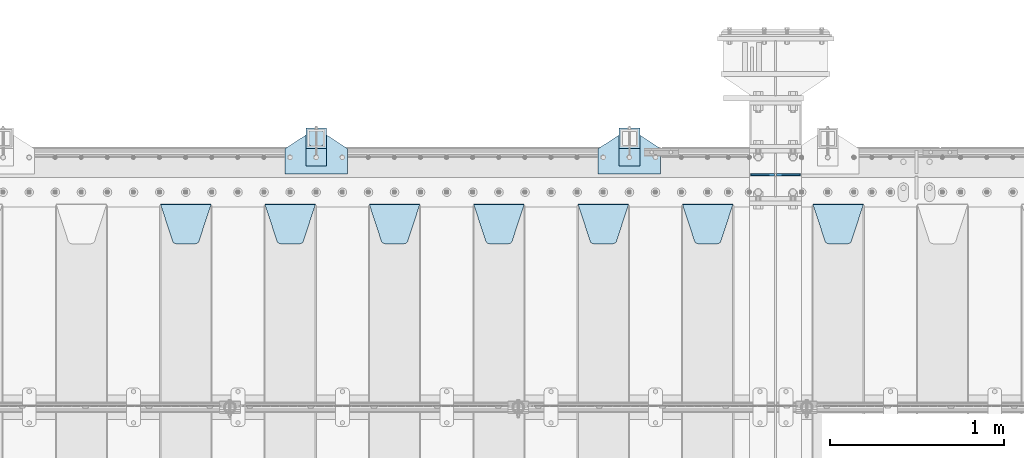
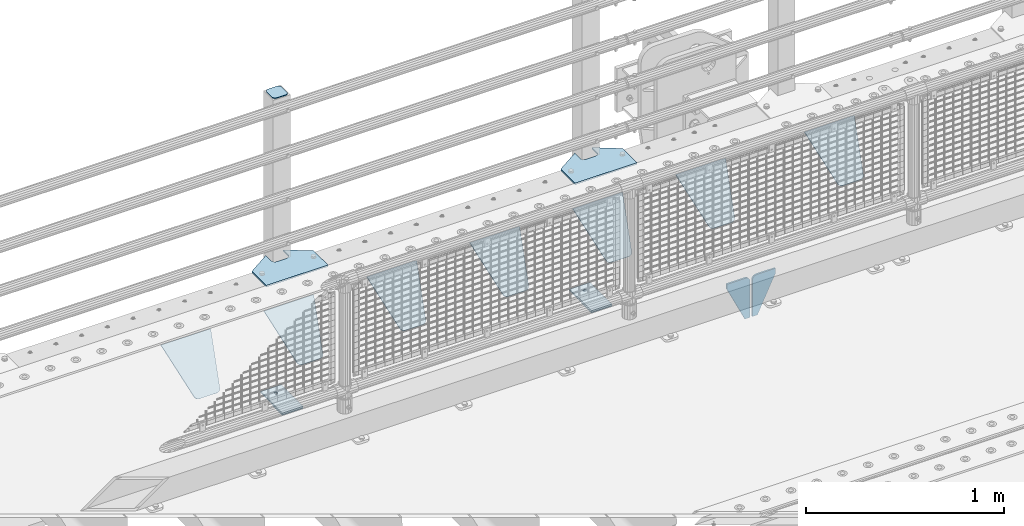
# One storey, part 224 of 240: 16 plates.
"""IFC2X3 building model written with IfcOpenShell, lengths in millimetres."""

from ifc_helpers import new_model, si_unit, frame, origin_with_axes, place, context, subcontext, project, spatial, faceted_brep, material, type_object, element, save


model = new_model("IFC2X3")

# Units and contexts
model_context = context("Model", 3, precision=1e-05, world=origin_with_axes())
body_context = subcontext(model_context, "Body", "Model", "MODEL_VIEW")
ifc_project = project(units=[si_unit("LENGTHUNIT", "METRE", prefix="MILLI"), si_unit("AREAUNIT", "SQUARE_METRE"), si_unit("VOLUMEUNIT", "CUBIC_METRE"), si_unit("MASSUNIT", "GRAM", prefix="KILO"), si_unit("TIMEUNIT", "SECOND"), si_unit("PLANEANGLEUNIT", "RADIAN"), si_unit("SOLIDANGLEUNIT", "STERADIAN"), si_unit("THERMODYNAMICTEMPERATUREUNIT", "DEGREE_CELSIUS"), si_unit("LUMINOUSINTENSITYUNIT", "LUMEN")], contexts=[model_context])

# Site, building, storey
site_placement = place(None, origin_with_axes())
site = spatial("IfcSite", under=ifc_project, at=site_placement, CompositionType="ELEMENT")
building_placement = place(site_placement, origin_with_axes())
building = spatial("IfcBuilding", under=site, at=building_placement, Name="Standard", CompositionType="ELEMENT")
storey_placement = place(building_placement, origin_with_axes())
storey = spatial("IfcBuildingStorey", under=building, at=storey_placement, Name="Undefined", CompositionType="ELEMENT", Elevation=0.0)

# Plates
ifc_material_1 = material(Name="STEEL/S355N")
plate_type_1 = type_object("IfcPlateType", PredefinedType="NOTDEFINED")
for number, where, z_axis, x_axis in (
    (1, (52833.499999996, 36000.0000000345, -915.000018222272), (0.0, 0.0, -1.0), (-1.0, 0.0, 0.0)),
    (2, (52846.4999999962, 36000.0000000345, -915.000018222272), (0.0, 0.0, -1.0), (1.0, 0.0, 0.0)),
):
    element("IfcPlate", number, at=place(storey_placement, frame(where, z_axis=z_axis, x_axis=x_axis)), inside=storey, type_object=plate_type_1, material=ifc_material_1, context=body_context, shape_type="Brep", body=[
        faceted_brep([(0.0, -5.0, 27.0), (0.0, -5.0, 250.0), (0.0, 5.0, 250.0), (0.0, 5.0, 27.0), (30.0, -5.0, 250.0), (30.0, 5.0, 250.0), (135.0, -5.0, 30.0), (135.0, 5.0, 30.0), (135.0, -5.0, 0.0), (135.0, 5.0, 0.0), (27.0, -5.0, 0.0), (27.0, 5.0, 0.0), (22.311499202995, -5.0, 0.410190668670339), (22.311499202995, 5.0, 0.410190668670339), (17.7654561302043, -5.0, 1.62829923878053), (17.7654561302043, 5.0, 1.62829923878053), (13.5, -5.0, 3.6173140978201), (13.5, 5.0, 3.6173140978201), (9.64473453846585, -5.0, 6.31680003578754), (9.64473453846585, 5.0, 6.31680003578754), (6.31680003579095, -5.0, 9.64473453846347), (6.31680003579095, 5.0, 9.64473453846347), (3.61731409782078, -5.0, 13.5), (3.61731409782078, 5.0, 13.5), (1.62829923877871, -5.0, 17.765456130207), (1.62829923877871, 5.0, 17.765456130207), (0.410190668670111, -5.0, 22.3114992029929), (0.410190668670111, 5.0, 22.3114992029929)], [[[0, 1, 2, 3]], [[1, 4, 5, 2]], [[4, 6, 7, 5]], [[6, 8, 9, 7]], [[8, 10, 11, 9]], [[10, 12, 13, 11]], [[12, 14, 15, 13]], [[14, 16, 17, 15]], [[16, 18, 19, 17]], [[18, 20, 21, 19]], [[20, 22, 23, 21]], [[22, 24, 25, 23]], [[24, 26, 27, 25]], [[26, 0, 3, 27]], [[5, 7, 9, 11, 13, 15, 17, 19, 21, 23, 25, 27, 3, 2]], [[26, 24, 22, 20, 18, 16, 14, 12, 10, 8, 6, 4, 1, 0]]]),
    ])
plate_type_2 = type_object("IfcPlateType", PredefinedType="NOTDEFINED")
plate_1_placement = place(storey_placement, frame((53055.0, 35831.767766956, -1.76776695296758), z_axis=(0.0, -0.707106781186547, -0.707106781186548), x_axis=(1.0, 0.0, 0.0)))
element("IfcPlate", 3, at=plate_1_placement, inside=storey, type_object=plate_type_2, material=ifc_material_1, context=body_context, shape_type="Brep", body=[
    faceted_brep([(0.0, -2.5, 0.0), (69.345504679477, -2.50000000000364, 300.171731424827), (69.345504679477, 2.49999999999636, 300.171731424827), (0.0, 2.5, 0.0), (70.927406119954, -2.50000000000364, 304.897442415397), (70.927406119954, 2.49999999999636, 304.897442415397), (73.3818627772271, -2.50000000000728, 309.234538108525), (73.3818627772271, 2.49999999999636, 309.234538108529), (76.6187032999587, -2.50000000000728, 313.023683126099), (76.6187032999587, 2.49999999999636, 313.023683126103), (80.5190132705029, -2.50000000000364, 316.125672595368), (80.5190132705029, 2.49999999999636, 316.125672595368), (84.9395038596849, -2.50000000000364, 318.426546230472), (84.9395038596849, 2.49999999999636, 318.426546230472), (89.7177759439219, -2.5, 319.841774983277), (89.7177759439219, 2.49999999999636, 319.841774983273), (94.6782862926484, -2.50000000000364, 320.319366455074), (94.6782862926484, 2.49999999999636, 320.319366455074), (195.321713707352, -2.50000000000364, 320.319366455074), (195.321713707352, 2.49999999999636, 320.319366455074), (200.282224056078, -2.50000000000364, 319.841774983273), (200.282224056078, 2.49999999999636, 319.841774983273), (205.060496140315, -2.50000000000364, 318.426546230472), (205.060496140315, 2.49999999999636, 318.426546230472), (209.480986729497, -2.50000000000364, 316.125672595368), (209.480986729497, 2.49999999999636, 316.125672595368), (213.381296700041, -2.50000000000728, 313.023683126099), (213.381296700041, 2.49999999999272, 313.023683126099), (216.618137222766, -2.50000000000364, 309.234538108522), (216.618137222766, 2.49999999999636, 309.234538108522), (219.072593880039, -2.50000000000364, 304.897442415397), (219.072593880039, 2.49999999999636, 304.897442415397), (220.654495320523, -2.50000000000364, 300.171731424827), (220.654495320523, 2.49999999999636, 300.171731424827), (290.0, -2.50000000000364, -3.63797880709171e-12), (290.0, 2.49999999999636, -3.63797880709171e-12)], [[[0, 1, 2, 3]], [[1, 4, 5, 2]], [[4, 6, 7, 5]], [[6, 8, 9, 7]], [[8, 10, 11, 9]], [[10, 12, 13, 11]], [[12, 14, 15, 13]], [[14, 16, 17, 15]], [[16, 18, 19, 17]], [[18, 20, 21, 19]], [[20, 22, 23, 21]], [[22, 24, 25, 23]], [[24, 26, 27, 25]], [[26, 28, 29, 27]], [[28, 30, 31, 29]], [[30, 32, 33, 31]], [[32, 34, 35, 33]], [[34, 0, 3, 35]], [[5, 7, 9, 11, 13, 15, 17, 19, 21, 23, 25, 27, 29, 31, 33, 35, 3, 2]], [[34, 32, 30, 28, 26, 24, 22, 20, 18, 16, 14, 12, 10, 8, 6, 4, 1, 0]]]),
])
plate_2_placement = place(storey_placement, frame((52305.0, 35831.767766956, -1.76776695296758), z_axis=(0.0, -0.707106781186547, -0.707106781186548), x_axis=(1.0, 0.0, 0.0)))
element("IfcPlate", 4, at=plate_2_placement, inside=storey, type_object=plate_type_2, material=ifc_material_1, context=body_context, shape_type="Brep", body=[
    faceted_brep([(0.0, -2.5, 0.0), (69.345504679477, -2.50000000000364, 300.171731424827), (69.345504679477, 2.49999999999636, 300.171731424827), (0.0, 2.5, 0.0), (70.927406119954, -2.50000000000364, 304.897442415397), (70.927406119954, 2.49999999999636, 304.897442415397), (73.3818627772271, -2.50000000000728, 309.234538108525), (73.3818627772271, 2.49999999999636, 309.234538108529), (76.6187032999587, -2.50000000000728, 313.023683126099), (76.6187032999587, 2.49999999999636, 313.023683126103), (80.5190132705029, -2.50000000000364, 316.125672595368), (80.5190132705029, 2.49999999999636, 316.125672595368), (84.9395038596849, -2.50000000000364, 318.426546230472), (84.9395038596849, 2.49999999999636, 318.426546230472), (89.7177759439219, -2.5, 319.841774983277), (89.7177759439219, 2.49999999999636, 319.841774983273), (94.6782862926484, -2.50000000000364, 320.319366455074), (94.6782862926484, 2.49999999999636, 320.319366455074), (195.321713707352, -2.50000000000364, 320.319366455074), (195.321713707352, 2.49999999999636, 320.319366455074), (200.282224056078, -2.50000000000364, 319.841774983273), (200.282224056078, 2.49999999999636, 319.841774983273), (205.060496140315, -2.50000000000364, 318.426546230472), (205.060496140315, 2.49999999999636, 318.426546230472), (209.480986729497, -2.50000000000364, 316.125672595368), (209.480986729497, 2.49999999999636, 316.125672595368), (213.381296700041, -2.50000000000728, 313.023683126099), (213.381296700041, 2.49999999999272, 313.023683126099), (216.618137222766, -2.50000000000364, 309.234538108522), (216.618137222766, 2.49999999999636, 309.234538108522), (219.072593880039, -2.50000000000364, 304.897442415397), (219.072593880039, 2.49999999999636, 304.897442415397), (220.654495320523, -2.50000000000364, 300.171731424827), (220.654495320523, 2.49999999999636, 300.171731424827), (290.0, -2.50000000000364, -3.63797880709171e-12), (290.0, 2.49999999999636, -3.63797880709171e-12)], [[[0, 1, 2, 3]], [[1, 4, 5, 2]], [[4, 6, 7, 5]], [[6, 8, 9, 7]], [[8, 10, 11, 9]], [[10, 12, 13, 11]], [[12, 14, 15, 13]], [[14, 16, 17, 15]], [[16, 18, 19, 17]], [[18, 20, 21, 19]], [[20, 22, 23, 21]], [[22, 24, 25, 23]], [[24, 26, 27, 25]], [[26, 28, 29, 27]], [[28, 30, 31, 29]], [[30, 32, 33, 31]], [[32, 34, 35, 33]], [[34, 0, 3, 35]], [[5, 7, 9, 11, 13, 15, 17, 19, 21, 23, 25, 27, 29, 31, 33, 35, 3, 2]], [[34, 32, 30, 28, 26, 24, 22, 20, 18, 16, 14, 12, 10, 8, 6, 4, 1, 0]]]),
])
plate_3_placement = place(storey_placement, frame((51705.0, 35831.767766956, -1.76776695296758), z_axis=(0.0, -0.707106781186547, -0.707106781186548), x_axis=(1.0, 0.0, 0.0)))
element("IfcPlate", 5, at=plate_3_placement, inside=storey, type_object=plate_type_2, material=ifc_material_1, context=body_context, shape_type="Brep", body=[
    faceted_brep([(0.0, -2.5, 0.0), (69.345504679477, -2.50000000000364, 300.171731424827), (69.345504679477, 2.49999999999636, 300.171731424827), (0.0, 2.5, 0.0), (70.927406119954, -2.50000000000364, 304.897442415397), (70.927406119954, 2.49999999999636, 304.897442415397), (73.3818627772271, -2.50000000000728, 309.234538108525), (73.3818627772271, 2.49999999999636, 309.234538108529), (76.6187032999587, -2.50000000000728, 313.023683126099), (76.6187032999587, 2.49999999999636, 313.023683126103), (80.5190132705029, -2.50000000000364, 316.125672595368), (80.5190132705029, 2.49999999999636, 316.125672595368), (84.9395038596849, -2.50000000000364, 318.426546230472), (84.9395038596849, 2.49999999999636, 318.426546230472), (89.7177759439219, -2.5, 319.841774983277), (89.7177759439219, 2.49999999999636, 319.841774983273), (94.6782862926484, -2.50000000000364, 320.319366455074), (94.6782862926484, 2.49999999999636, 320.319366455074), (195.321713707352, -2.50000000000364, 320.319366455074), (195.321713707352, 2.49999999999636, 320.319366455074), (200.282224056078, -2.50000000000364, 319.841774983273), (200.282224056078, 2.49999999999636, 319.841774983273), (205.060496140315, -2.50000000000364, 318.426546230472), (205.060496140315, 2.49999999999636, 318.426546230472), (209.480986729497, -2.50000000000364, 316.125672595368), (209.480986729497, 2.49999999999636, 316.125672595368), (213.381296700041, -2.50000000000728, 313.023683126099), (213.381296700041, 2.49999999999272, 313.023683126099), (216.618137222766, -2.50000000000364, 309.234538108522), (216.618137222766, 2.49999999999636, 309.234538108522), (219.072593880039, -2.50000000000364, 304.897442415397), (219.072593880039, 2.49999999999636, 304.897442415397), (220.654495320523, -2.50000000000364, 300.171731424827), (220.654495320523, 2.49999999999636, 300.171731424827), (290.0, -2.50000000000364, -3.63797880709171e-12), (290.0, 2.49999999999636, -3.63797880709171e-12)], [[[0, 1, 2, 3]], [[1, 4, 5, 2]], [[4, 6, 7, 5]], [[6, 8, 9, 7]], [[8, 10, 11, 9]], [[10, 12, 13, 11]], [[12, 14, 15, 13]], [[14, 16, 17, 15]], [[16, 18, 19, 17]], [[18, 20, 21, 19]], [[20, 22, 23, 21]], [[22, 24, 25, 23]], [[24, 26, 27, 25]], [[26, 28, 29, 27]], [[28, 30, 31, 29]], [[30, 32, 33, 31]], [[32, 34, 35, 33]], [[34, 0, 3, 35]], [[5, 7, 9, 11, 13, 15, 17, 19, 21, 23, 25, 27, 29, 31, 33, 35, 3, 2]], [[34, 32, 30, 28, 26, 24, 22, 20, 18, 16, 14, 12, 10, 8, 6, 4, 1, 0]]]),
])
plate_4_placement = place(storey_placement, frame((51105.0, 35831.767766956, -1.76776695296758), z_axis=(0.0, -0.707106781186547, -0.707106781186548), x_axis=(1.0, 0.0, 0.0)))
element("IfcPlate", 6, at=plate_4_placement, inside=storey, type_object=plate_type_2, material=ifc_material_1, context=body_context, shape_type="Brep", body=[
    faceted_brep([(0.0, -2.5, 0.0), (69.345504679477, -2.50000000000364, 300.171731424827), (69.345504679477, 2.49999999999636, 300.171731424827), (0.0, 2.5, 0.0), (70.927406119954, -2.50000000000364, 304.897442415397), (70.927406119954, 2.49999999999636, 304.897442415397), (73.3818627772271, -2.50000000000728, 309.234538108525), (73.3818627772271, 2.49999999999636, 309.234538108529), (76.6187032999587, -2.50000000000728, 313.023683126099), (76.6187032999587, 2.49999999999636, 313.023683126103), (80.5190132705029, -2.50000000000364, 316.125672595368), (80.5190132705029, 2.49999999999636, 316.125672595368), (84.9395038596849, -2.50000000000364, 318.426546230472), (84.9395038596849, 2.49999999999636, 318.426546230472), (89.7177759439219, -2.5, 319.841774983277), (89.7177759439219, 2.49999999999636, 319.841774983273), (94.6782862926484, -2.50000000000364, 320.319366455074), (94.6782862926484, 2.49999999999636, 320.319366455074), (195.321713707352, -2.50000000000364, 320.319366455074), (195.321713707352, 2.49999999999636, 320.319366455074), (200.282224056078, -2.50000000000364, 319.841774983273), (200.282224056078, 2.49999999999636, 319.841774983273), (205.060496140315, -2.50000000000364, 318.426546230472), (205.060496140315, 2.49999999999636, 318.426546230472), (209.480986729497, -2.50000000000364, 316.125672595368), (209.480986729497, 2.49999999999636, 316.125672595368), (213.381296700041, -2.50000000000728, 313.023683126099), (213.381296700041, 2.49999999999272, 313.023683126099), (216.618137222766, -2.50000000000364, 309.234538108522), (216.618137222766, 2.49999999999636, 309.234538108522), (219.072593880039, -2.50000000000364, 304.897442415397), (219.072593880039, 2.49999999999636, 304.897442415397), (220.654495320523, -2.50000000000364, 300.171731424827), (220.654495320523, 2.49999999999636, 300.171731424827), (290.0, -2.50000000000364, -3.63797880709171e-12), (290.0, 2.49999999999636, -3.63797880709171e-12)], [[[0, 1, 2, 3]], [[1, 4, 5, 2]], [[4, 6, 7, 5]], [[6, 8, 9, 7]], [[8, 10, 11, 9]], [[10, 12, 13, 11]], [[12, 14, 15, 13]], [[14, 16, 17, 15]], [[16, 18, 19, 17]], [[18, 20, 21, 19]], [[20, 22, 23, 21]], [[22, 24, 25, 23]], [[24, 26, 27, 25]], [[26, 28, 29, 27]], [[28, 30, 31, 29]], [[30, 32, 33, 31]], [[32, 34, 35, 33]], [[34, 0, 3, 35]], [[5, 7, 9, 11, 13, 15, 17, 19, 21, 23, 25, 27, 29, 31, 33, 35, 3, 2]], [[34, 32, 30, 28, 26, 24, 22, 20, 18, 16, 14, 12, 10, 8, 6, 4, 1, 0]]]),
])
plate_5_placement = place(storey_placement, frame((50505.0, 35831.767766956, -1.76776695296758), z_axis=(0.0, -0.707106781186547, -0.707106781186548), x_axis=(1.0, 0.0, 0.0)))
element("IfcPlate", 7, at=plate_5_placement, inside=storey, type_object=plate_type_2, material=ifc_material_1, context=body_context, shape_type="Brep", body=[
    faceted_brep([(0.0, -2.5, 0.0), (69.345504679477, -2.50000000000364, 300.171731424827), (69.345504679477, 2.49999999999636, 300.171731424827), (0.0, 2.5, 0.0), (70.927406119954, -2.50000000000364, 304.897442415397), (70.927406119954, 2.49999999999636, 304.897442415397), (73.3818627772271, -2.50000000000728, 309.234538108525), (73.3818627772271, 2.49999999999636, 309.234538108529), (76.6187032999587, -2.50000000000728, 313.023683126099), (76.6187032999587, 2.49999999999636, 313.023683126103), (80.5190132705029, -2.50000000000364, 316.125672595368), (80.5190132705029, 2.49999999999636, 316.125672595368), (84.9395038596849, -2.50000000000364, 318.426546230472), (84.9395038596849, 2.49999999999636, 318.426546230472), (89.7177759439219, -2.5, 319.841774983277), (89.7177759439219, 2.49999999999636, 319.841774983273), (94.6782862926484, -2.50000000000364, 320.319366455074), (94.6782862926484, 2.49999999999636, 320.319366455074), (195.321713707352, -2.50000000000364, 320.319366455074), (195.321713707352, 2.49999999999636, 320.319366455074), (200.282224056078, -2.50000000000364, 319.841774983273), (200.282224056078, 2.49999999999636, 319.841774983273), (205.060496140315, -2.50000000000364, 318.426546230472), (205.060496140315, 2.49999999999636, 318.426546230472), (209.480986729497, -2.50000000000364, 316.125672595368), (209.480986729497, 2.49999999999636, 316.125672595368), (213.381296700041, -2.50000000000728, 313.023683126099), (213.381296700041, 2.49999999999272, 313.023683126099), (216.618137222766, -2.50000000000364, 309.234538108522), (216.618137222766, 2.49999999999636, 309.234538108522), (219.072593880039, -2.50000000000364, 304.897442415397), (219.072593880039, 2.49999999999636, 304.897442415397), (220.654495320523, -2.50000000000364, 300.171731424827), (220.654495320523, 2.49999999999636, 300.171731424827), (290.0, -2.50000000000364, -3.63797880709171e-12), (290.0, 2.49999999999636, -3.63797880709171e-12)], [[[0, 1, 2, 3]], [[1, 4, 5, 2]], [[4, 6, 7, 5]], [[6, 8, 9, 7]], [[8, 10, 11, 9]], [[10, 12, 13, 11]], [[12, 14, 15, 13]], [[14, 16, 17, 15]], [[16, 18, 19, 17]], [[18, 20, 21, 19]], [[20, 22, 23, 21]], [[22, 24, 25, 23]], [[24, 26, 27, 25]], [[26, 28, 29, 27]], [[28, 30, 31, 29]], [[30, 32, 33, 31]], [[32, 34, 35, 33]], [[34, 0, 3, 35]], [[5, 7, 9, 11, 13, 15, 17, 19, 21, 23, 25, 27, 29, 31, 33, 35, 3, 2]], [[34, 32, 30, 28, 26, 24, 22, 20, 18, 16, 14, 12, 10, 8, 6, 4, 1, 0]]]),
])
plate_6_placement = place(storey_placement, frame((49905.0, 35831.767766956, -1.76776695296758), z_axis=(0.0, -0.707106781186547, -0.707106781186548), x_axis=(1.0, 0.0, 0.0)))
element("IfcPlate", 8, at=plate_6_placement, inside=storey, type_object=plate_type_2, material=ifc_material_1, context=body_context, shape_type="Brep", body=[
    faceted_brep([(0.0, -2.5, 0.0), (69.345504679477, -2.50000000000364, 300.171731424827), (69.345504679477, 2.49999999999636, 300.171731424827), (0.0, 2.5, 0.0), (70.927406119954, -2.50000000000364, 304.897442415397), (70.927406119954, 2.49999999999636, 304.897442415397), (73.3818627772271, -2.50000000000728, 309.234538108525), (73.3818627772271, 2.49999999999636, 309.234538108529), (76.6187032999587, -2.50000000000728, 313.023683126099), (76.6187032999587, 2.49999999999636, 313.023683126103), (80.5190132705029, -2.50000000000364, 316.125672595368), (80.5190132705029, 2.49999999999636, 316.125672595368), (84.9395038596849, -2.50000000000364, 318.426546230472), (84.9395038596849, 2.49999999999636, 318.426546230472), (89.7177759439219, -2.5, 319.841774983277), (89.7177759439219, 2.49999999999636, 319.841774983273), (94.6782862926484, -2.50000000000364, 320.319366455074), (94.6782862926484, 2.49999999999636, 320.319366455074), (195.321713707352, -2.50000000000364, 320.319366455074), (195.321713707352, 2.49999999999636, 320.319366455074), (200.282224056078, -2.50000000000364, 319.841774983273), (200.282224056078, 2.49999999999636, 319.841774983273), (205.060496140315, -2.50000000000364, 318.426546230472), (205.060496140315, 2.49999999999636, 318.426546230472), (209.480986729497, -2.50000000000364, 316.125672595368), (209.480986729497, 2.49999999999636, 316.125672595368), (213.381296700041, -2.50000000000728, 313.023683126099), (213.381296700041, 2.49999999999272, 313.023683126099), (216.618137222766, -2.50000000000364, 309.234538108522), (216.618137222766, 2.49999999999636, 309.234538108522), (219.072593880039, -2.50000000000364, 304.897442415397), (219.072593880039, 2.49999999999636, 304.897442415397), (220.654495320523, -2.50000000000364, 300.171731424827), (220.654495320523, 2.49999999999636, 300.171731424827), (290.0, -2.50000000000364, -3.63797880709171e-12), (290.0, 2.49999999999636, -3.63797880709171e-12)], [[[0, 1, 2, 3]], [[1, 4, 5, 2]], [[4, 6, 7, 5]], [[6, 8, 9, 7]], [[8, 10, 11, 9]], [[10, 12, 13, 11]], [[12, 14, 15, 13]], [[14, 16, 17, 15]], [[16, 18, 19, 17]], [[18, 20, 21, 19]], [[20, 22, 23, 21]], [[22, 24, 25, 23]], [[24, 26, 27, 25]], [[26, 28, 29, 27]], [[28, 30, 31, 29]], [[30, 32, 33, 31]], [[32, 34, 35, 33]], [[34, 0, 3, 35]], [[5, 7, 9, 11, 13, 15, 17, 19, 21, 23, 25, 27, 29, 31, 33, 35, 3, 2]], [[34, 32, 30, 28, 26, 24, 22, 20, 18, 16, 14, 12, 10, 8, 6, 4, 1, 0]]]),
])
plate_7_placement = place(storey_placement, frame((49305.0, 35831.767766956, -1.76776695296758), z_axis=(0.0, -0.707106781186547, -0.707106781186548), x_axis=(1.0, 0.0, 0.0)))
element("IfcPlate", 9, at=plate_7_placement, inside=storey, type_object=plate_type_2, material=ifc_material_1, context=body_context, shape_type="Brep", body=[
    faceted_brep([(0.0, -2.5, 0.0), (69.345504679477, -2.50000000000364, 300.171731424827), (69.345504679477, 2.49999999999636, 300.171731424827), (0.0, 2.5, 0.0), (70.927406119954, -2.50000000000364, 304.897442415397), (70.927406119954, 2.49999999999636, 304.897442415397), (73.3818627772271, -2.50000000000728, 309.234538108525), (73.3818627772271, 2.49999999999636, 309.234538108529), (76.6187032999587, -2.50000000000728, 313.023683126099), (76.6187032999587, 2.49999999999636, 313.023683126103), (80.5190132705029, -2.50000000000364, 316.125672595368), (80.5190132705029, 2.49999999999636, 316.125672595368), (84.9395038596849, -2.50000000000364, 318.426546230472), (84.9395038596849, 2.49999999999636, 318.426546230472), (89.7177759439219, -2.5, 319.841774983277), (89.7177759439219, 2.49999999999636, 319.841774983273), (94.6782862926484, -2.50000000000364, 320.319366455074), (94.6782862926484, 2.49999999999636, 320.319366455074), (195.321713707352, -2.50000000000364, 320.319366455074), (195.321713707352, 2.49999999999636, 320.319366455074), (200.282224056078, -2.50000000000364, 319.841774983273), (200.282224056078, 2.49999999999636, 319.841774983273), (205.060496140315, -2.50000000000364, 318.426546230472), (205.060496140315, 2.49999999999636, 318.426546230472), (209.480986729497, -2.50000000000364, 316.125672595368), (209.480986729497, 2.49999999999636, 316.125672595368), (213.381296700041, -2.50000000000728, 313.023683126099), (213.381296700041, 2.49999999999272, 313.023683126099), (216.618137222766, -2.50000000000364, 309.234538108522), (216.618137222766, 2.49999999999636, 309.234538108522), (219.072593880039, -2.50000000000364, 304.897442415397), (219.072593880039, 2.49999999999636, 304.897442415397), (220.654495320523, -2.50000000000364, 300.171731424827), (220.654495320523, 2.49999999999636, 300.171731424827), (290.0, -2.50000000000364, -3.63797880709171e-12), (290.0, 2.49999999999636, -3.63797880709171e-12)], [[[0, 1, 2, 3]], [[1, 4, 5, 2]], [[4, 6, 7, 5]], [[6, 8, 9, 7]], [[8, 10, 11, 9]], [[10, 12, 13, 11]], [[12, 14, 15, 13]], [[14, 16, 17, 15]], [[16, 18, 19, 17]], [[18, 20, 21, 19]], [[20, 22, 23, 21]], [[22, 24, 25, 23]], [[24, 26, 27, 25]], [[26, 28, 29, 27]], [[28, 30, 31, 29]], [[30, 32, 33, 31]], [[32, 34, 35, 33]], [[34, 0, 3, 35]], [[5, 7, 9, 11, 13, 15, 17, 19, 21, 23, 25, 27, 29, 31, 33, 35, 3, 2]], [[34, 32, 30, 28, 26, 24, 22, 20, 18, 16, 14, 12, 10, 8, 6, 4, 1, 0]]]),
])
ifc_material_2 = material(Name="STEEL/S355J2")
plate_type_3 = type_object("IfcPlateType", PredefinedType="NOTDEFINED")
plate_8_placement = place(storey_placement, frame((51820.0, 36005.0, 5.00000000004911), z_axis=(0.0, 1.0, 0.0), x_axis=(1.0, 0.0, 0.0)))
element("IfcPlate", 10, at=plate_8_placement, inside=storey, type_object=plate_type_3, material=ifc_material_2, context=body_context, shape_type="Brep", body=[
    faceted_brep([(0.0, -5.0, 0.0), (2.31396552408114e-06, -5.0, 145.0), (2.31396552408114e-06, 5.0, 145.0), (0.0, 5.0, 0.0), (130.0, -5.0, 230.0), (130.0, 5.0, 230.0), (130.0, -5.0, 180.0), (130.0, 5.0, 180.0), (130.48036798992, -5.0, 175.122741949599), (130.48036798992, 5.0, 175.122741949599), (131.903011687216, -5.0, 170.432914190875), (131.903011687216, 5.0, 170.432914190875), (134.213259692435, -5.0, 166.110744174512), (134.213259692435, 5.0, 166.110744174512), (137.322330470335, -5.0, 162.322330470335), (137.322330470335, 5.0, 162.322330470335), (141.110744174512, -5.0, 159.213259692435), (141.110744174512, 5.0, 159.213259692435), (145.432914190875, -5.0, 156.903011687216), (145.432914190875, 5.0, 156.903011687216), (150.122741949599, -5.0, 155.48036798992), (150.122741949599, 5.0, 155.48036798992), (155.0, -5.0, 155.0), (155.0, 5.0, 155.0), (205.0, -5.0, 155.0), (205.0, 5.0, 155.0), (209.877258050401, -5.0, 155.48036798992), (209.877258050401, 5.0, 155.48036798992), (214.567085809125, -5.0, 156.903011687216), (214.567085809125, 5.0, 156.903011687216), (218.889255825488, -5.0, 159.213259692435), (218.889255825488, 5.0, 159.213259692435), (222.677669529665, -5.0, 162.322330470335), (222.677669529665, 5.0, 162.322330470335), (225.786740307565, -5.0, 166.110744174512), (225.786740307565, 5.0, 166.110744174512), (228.096988312784, -5.0, 170.432914190875), (228.096988312784, 5.0, 170.432914190875), (229.51963201008, -5.0, 175.122741949599), (229.51963201008, 5.0, 175.122741949599), (230.0, -5.0, 180.0), (230.0, 5.0, 180.0), (230.0, -5.0, 230.0), (230.0, 5.0, 230.0), (360.0, -5.0, 145.0), (360.0, 5.0, 145.0), (360.0, -5.0, -7.27595761418343e-12), (360.0, 5.0, -7.27595761418343e-12)], [[[0, 1, 2, 3]], [[1, 4, 5, 2]], [[4, 6, 7, 5]], [[6, 8, 9, 7]], [[8, 10, 11, 9]], [[10, 12, 13, 11]], [[12, 14, 15, 13]], [[14, 16, 17, 15]], [[16, 18, 19, 17]], [[18, 20, 21, 19]], [[20, 22, 23, 21]], [[22, 24, 25, 23]], [[24, 26, 27, 25]], [[26, 28, 29, 27]], [[28, 30, 31, 29]], [[30, 32, 33, 31]], [[32, 34, 35, 33]], [[34, 36, 37, 35]], [[36, 38, 39, 37]], [[38, 40, 41, 39]], [[40, 42, 43, 41]], [[42, 44, 45, 43]], [[44, 46, 47, 45]], [[46, 0, 3, 47]], [[5, 7, 9, 11, 13, 15, 17, 19, 21, 23, 25, 27, 29, 31, 33, 35, 37, 39, 41, 43, 45, 47, 3, 2]], [[46, 44, 42, 40, 38, 36, 34, 32, 30, 28, 26, 24, 22, 20, 18, 16, 14, 12, 10, 8, 6, 4, 1, 0]]]),
])
plate_9_placement = place(storey_placement, frame((50020.0, 36005.0, 5.00000000004911), z_axis=(0.0, 1.0, 0.0), x_axis=(1.0, 0.0, 0.0)))
element("IfcPlate", 11, at=plate_9_placement, inside=storey, type_object=plate_type_3, material=ifc_material_2, context=body_context, shape_type="Brep", body=[
    faceted_brep([(0.0, -5.0, 0.0), (2.31396552408114e-06, -5.0, 145.0), (2.31396552408114e-06, 5.0, 145.0), (0.0, 5.0, 0.0), (130.0, -5.0, 230.0), (130.0, 5.0, 230.0), (130.0, -5.0, 180.0), (130.0, 5.0, 180.0), (130.48036798992, -5.0, 175.122741949599), (130.48036798992, 5.0, 175.122741949599), (131.903011687216, -5.0, 170.432914190875), (131.903011687216, 5.0, 170.432914190875), (134.213259692435, -5.0, 166.110744174512), (134.213259692435, 5.0, 166.110744174512), (137.322330470335, -5.0, 162.322330470335), (137.322330470335, 5.0, 162.322330470335), (141.110744174512, -5.0, 159.213259692435), (141.110744174512, 5.0, 159.213259692435), (145.432914190875, -5.0, 156.903011687216), (145.432914190875, 5.0, 156.903011687216), (150.122741949599, -5.0, 155.48036798992), (150.122741949599, 5.0, 155.48036798992), (155.0, -5.0, 155.0), (155.0, 5.0, 155.0), (205.0, -5.0, 155.0), (205.0, 5.0, 155.0), (209.877258050401, -5.0, 155.48036798992), (209.877258050401, 5.0, 155.48036798992), (214.567085809125, -5.0, 156.903011687216), (214.567085809125, 5.0, 156.903011687216), (218.889255825488, -5.0, 159.213259692435), (218.889255825488, 5.0, 159.213259692435), (222.677669529665, -5.0, 162.322330470335), (222.677669529665, 5.0, 162.322330470335), (225.786740307565, -5.0, 166.110744174512), (225.786740307565, 5.0, 166.110744174512), (228.096988312784, -5.0, 170.432914190875), (228.096988312784, 5.0, 170.432914190875), (229.51963201008, -5.0, 175.122741949599), (229.51963201008, 5.0, 175.122741949599), (230.0, -5.0, 180.0), (230.0, 5.0, 180.0), (230.0, -5.0, 230.0), (230.0, 5.0, 230.0), (360.0, -5.0, 145.0), (360.0, 5.0, 145.0), (360.0, -5.0, -7.27595761418343e-12), (360.0, 5.0, -7.27595761418343e-12)], [[[0, 1, 2, 3]], [[1, 4, 5, 2]], [[4, 6, 7, 5]], [[6, 8, 9, 7]], [[8, 10, 11, 9]], [[10, 12, 13, 11]], [[12, 14, 15, 13]], [[14, 16, 17, 15]], [[16, 18, 19, 17]], [[18, 20, 21, 19]], [[20, 22, 23, 21]], [[22, 24, 25, 23]], [[24, 26, 27, 25]], [[26, 28, 29, 27]], [[28, 30, 31, 29]], [[30, 32, 33, 31]], [[32, 34, 35, 33]], [[34, 36, 37, 35]], [[36, 38, 39, 37]], [[38, 40, 41, 39]], [[40, 42, 43, 41]], [[42, 44, 45, 43]], [[44, 46, 47, 45]], [[46, 0, 3, 47]], [[5, 7, 9, 11, 13, 15, 17, 19, 21, 23, 25, 27, 29, 31, 33, 35, 37, 39, 41, 43, 45, 47, 3, 2]], [[46, 44, 42, 40, 38, 36, 34, 32, 30, 28, 26, 24, 22, 20, 18, 16, 14, 12, 10, 8, 6, 4, 1, 0]]]),
])
plate_type_4 = type_object("IfcPlateType", PredefinedType="NOTDEFINED")
for number, where, z_axis, x_axis in (
    (12, (51940.0000000001, 36050.0000000002, -850.000000000002), (0.0, 1.0, 0.0), (1.0, 0.0, 0.0)),
    (13, (50140.0000000001, 36050.0000000002, -850.000000000002), (0.0, 1.0, 0.0), (1.0, 0.0, 0.0)),
):
    element("IfcPlate", number, at=place(storey_placement, frame(where, z_axis=z_axis, x_axis=x_axis)), inside=storey, type_object=plate_type_4, material=ifc_material_2, context=body_context, shape_type="Brep", body=[
        faceted_brep([(66.3639610305399, -5.0, 163.636038969111), (66.3639610305399, 5.0, 163.636038969111), (59.9999999998618, 5.0, 160.999999999789), (59.9999999998618, -5.0, 160.999999999789), (53.6360389691836, 5.0, 163.636038969111), (53.6360389691836, -5.0, 163.636038969111), (50.9999999998618, 5.0, 169.999999999789), (50.9999999998618, -5.0, 169.999999999789), (53.6360389691836, 5.0, 176.363961030467), (53.6360389691836, -5.0, 176.363961030467), (59.9999999998618, 5.0, 178.999999999789), (59.9999999998618, -5.0, 178.999999999789), (66.3639610305399, 5.0, 176.363961030467), (66.3639610305399, -5.0, 176.363961030467), (68.9999999998618, 5.0, 169.999999999789), (68.9999999998618, -5.0, 169.999999999789), (120.0, -5.0, 0.0), (120.0, -5.0, 220.0), (0.0, -5.0, 220.0), (0.0, -5.0, 0.0), (0.0, 5.0, 0.0), (120.0, 5.0, 0.0), (120.0, 5.0, 220.0), (0.0, 5.0, 220.0)], [[[0, 1, 2, 3]], [[3, 2, 4, 5]], [[5, 4, 6, 7]], [[7, 6, 8, 9]], [[9, 8, 10, 11]], [[11, 10, 12, 13]], [[13, 12, 14, 15]], [[15, 14, 1, 0]], [[16, 17, 18, 19], [3, 5, 7, 9, 11, 13, 15, 0]], [[16, 19, 20, 21]], [[17, 16, 21, 22]], [[18, 17, 22, 23]], [[19, 18, 23, 20]], [[22, 21, 20, 23], [10, 8, 6, 4, 2, 1, 14, 12]]]),
    ])
plate_type_5 = type_object("IfcPlateType", PredefinedType="NOTDEFINED")
plate_10_placement = place(storey_placement, frame((50244.0000000001, 36166.0000000002, 1012.50000000001), z_axis=(0.0, 1.0, 0.0), x_axis=(-1.0, 0.0, 0.0)))
element("IfcPlate", 14, at=plate_10_placement, inside=storey, type_object=plate_type_5, material=ifc_material_2, context=body_context, shape_type="Brep", body=[
    faceted_brep([(0.0, -2.5, 19.0), (0.0, -2.5, 69.0), (0.0, 2.5, 69.0), (0.0, 2.5, 19.0), (0.476369668547704, -2.5, 73.2278977451715), (0.476369668547704, 2.5, 73.2278977451715), (1.88159150985302, -2.5, 77.2437910432345), (1.88159150985302, 2.5, 77.2437910432345), (4.14520183311106, -2.5, 80.8463062353185), (4.14520183311106, 2.5, 80.8463062353185), (7.15369376468152, -2.5, 83.8547981668889), (7.15369376468152, 2.5, 83.8547981668889), (10.7562089567655, -2.5, 86.118408490147), (10.7562089567655, 2.5, 86.118408490147), (14.7721022548285, -2.5, 87.5236303314523), (14.7721022548285, 2.5, 87.5236303314523), (19.0, -2.5, 88.0), (19.0, 2.5, 88.0), (69.0, -2.5, 88.0), (69.0, 2.5, 88.0), (73.2278977451715, -2.5, 87.5236303314523), (73.2278977451715, 2.5, 87.5236303314523), (77.2437910432345, -2.5, 86.118408490147), (77.2437910432345, 2.5, 86.118408490147), (80.8463062353185, -2.5, 83.8547981668889), (80.8463062353185, 2.5, 83.8547981668889), (83.8547981668889, -2.5, 80.8463062353185), (83.8547981668889, 2.5, 80.8463062353185), (86.118408490147, -2.5, 77.2437910432345), (86.118408490147, 2.5, 77.2437910432345), (87.5236303314523, -2.5, 73.2278977451715), (87.5236303314523, 2.5, 73.2278977451715), (88.0, -2.5, 69.0), (88.0, 2.5, 69.0), (88.0, -2.5, 19.0), (88.0, 2.5, 19.0), (87.5236303314523, -2.5, 14.7721022548285), (87.5236303314523, 2.5, 14.7721022548285), (86.118408490147, -2.5, 10.7562089567655), (86.118408490147, 2.5, 10.7562089567655), (83.8547981668889, -2.5, 7.15369376468152), (83.8547981668889, 2.5, 7.15369376468152), (80.8463062353185, -2.5, 4.14520183311106), (80.8463062353185, 2.5, 4.14520183311106), (77.2437910432345, -2.5, 1.88159150985302), (77.2437910432345, 2.5, 1.88159150985302), (73.2278977451715, -2.5, 0.476369668547704), (73.2278977451715, 2.5, 0.476369668547704), (69.0, -2.5, 0.0), (69.0, 2.5, 0.0), (19.0, -2.5, 0.0), (19.0, 2.5, 0.0), (14.7721022548285, -2.5, 0.476369668547704), (14.7721022548285, 2.5, 0.476369668547704), (10.7562089567655, -2.5, 1.88159150985302), (10.7562089567655, 2.5, 1.88159150985302), (7.15369376468152, -2.5, 4.14520183311106), (7.15369376468152, 2.5, 4.14520183311106), (4.14520183311106, -2.5, 7.15369376468152), (4.14520183311106, 2.5, 7.15369376468152), (1.88159150985302, -2.5, 10.7562089567655), (1.88159150985302, 2.5, 10.7562089567655), (0.476369668547704, -2.5, 14.7721022548285), (0.476369668547704, 2.5, 14.7721022548285)], [[[0, 1, 2, 3]], [[1, 4, 5, 2]], [[4, 6, 7, 5]], [[6, 8, 9, 7]], [[8, 10, 11, 9]], [[10, 12, 13, 11]], [[12, 14, 15, 13]], [[14, 16, 17, 15]], [[16, 18, 19, 17]], [[18, 20, 21, 19]], [[20, 22, 23, 21]], [[22, 24, 25, 23]], [[24, 26, 27, 25]], [[26, 28, 29, 27]], [[28, 30, 31, 29]], [[30, 32, 33, 31]], [[32, 34, 35, 33]], [[34, 36, 37, 35]], [[36, 38, 39, 37]], [[38, 40, 41, 39]], [[40, 42, 43, 41]], [[42, 44, 45, 43]], [[44, 46, 47, 45]], [[46, 48, 49, 47]], [[48, 50, 51, 49]], [[50, 52, 53, 51]], [[52, 54, 55, 53]], [[54, 56, 57, 55]], [[56, 58, 59, 57]], [[58, 60, 61, 59]], [[60, 62, 63, 61]], [[62, 0, 3, 63]], [[5, 7, 9, 11, 13, 15, 17, 19, 21, 23, 25, 27, 29, 31, 33, 35, 37, 39, 41, 43, 45, 47, 49, 51, 53, 55, 57, 59, 61, 63, 3, 2]], [[62, 60, 58, 56, 54, 52, 50, 48, 46, 44, 42, 40, 38, 36, 34, 32, 30, 28, 26, 24, 22, 20, 18, 16, 14, 12, 10, 8, 6, 4, 1, 0]]]),
])
plate_type_6 = type_object("IfcPlateType", PredefinedType="NOTDEFINED")
for number, where, z_axis, x_axis in (
    (15, (51940.0000000001, 36050.0000000002, -857.500000000002), (0.0, 1.0, 0.0), (1.0, 0.0, 0.0)),
    (16, (50140.0000000001, 36050.0000000002, -857.500000000002), (0.0, 1.0, 0.0), (1.0, 0.0, 0.0)),
):
    element("IfcPlate", number, at=place(storey_placement, frame(where, z_axis=z_axis, x_axis=x_axis)), inside=storey, type_object=plate_type_6, material=ifc_material_2, context=body_context, shape_type="Brep", body=[
        faceted_brep([(0.0, -2.5, 0.0), (0.0, -2.5, 100.0), (0.0, 2.5, 100.0), (0.0, 2.5, 0.0), (120.0, -2.5, 100.0), (120.0, 2.5, 100.0), (120.0, -2.5, 0.0), (120.0, 2.5, 0.0)], [[[0, 1, 2, 3]], [[1, 4, 5, 2]], [[4, 6, 7, 5]], [[6, 0, 3, 7]], [[5, 7, 3, 2]], [[6, 4, 1, 0]]]),
    ])

save(model, "model.ifc")
